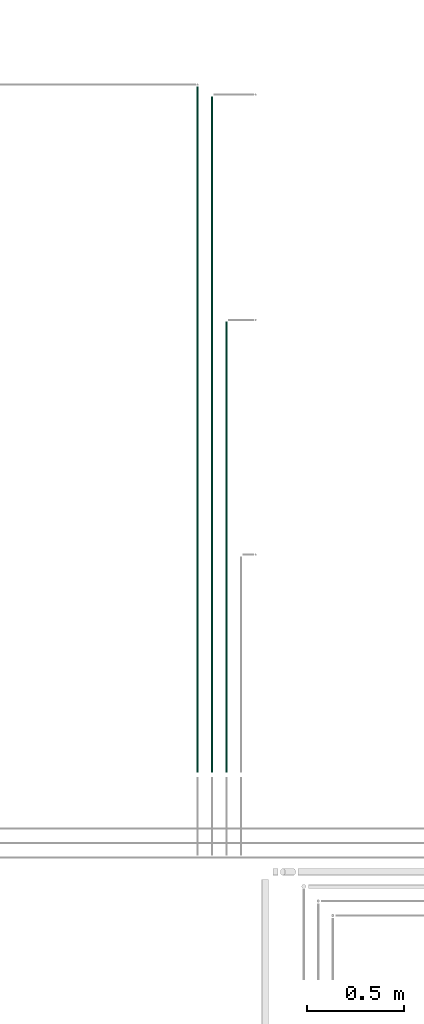
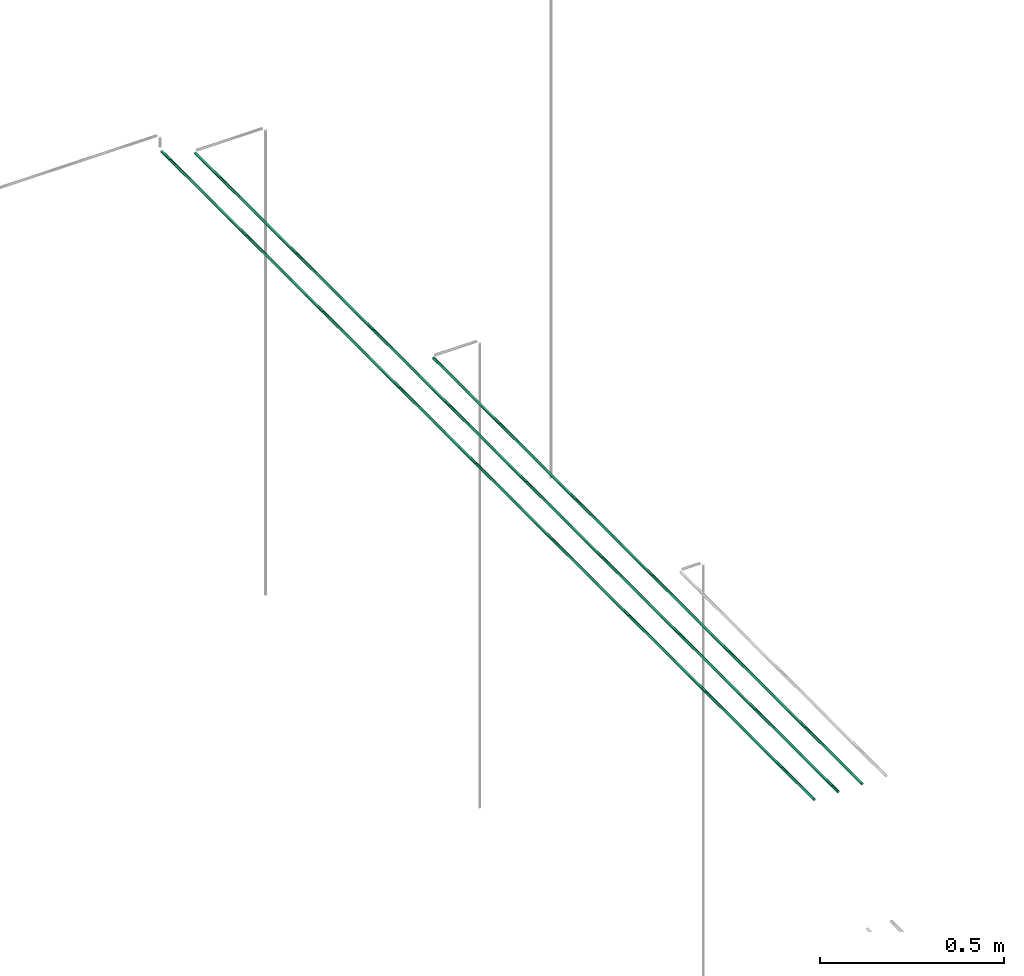
# One storey, part 27 of 331: 3 flow segments.
"""IFC2X3 building model written with IfcOpenShell, lengths in millimetres."""

from ifc_helpers import new_model, entity, si_unit, converted_unit, derived_unit, direction, frame, frame_2d, origin, place, context, subcontext, project, spatial, circle, extrude, type_object, element, save


model = new_model("IFC2X3")

# Units and contexts
model_context = context("Model", 3, precision=0.01, world=origin(), true_north=direction((6.12303176911189e-17, 1.0)))
body_context = subcontext(model_context, "Body", "Model", "MODEL_VIEW")
ifc_project = project(units=[si_unit("LENGTHUNIT", "METRE", prefix="MILLI"), si_unit("AREAUNIT", "SQUARE_METRE"), si_unit("VOLUMEUNIT", "CUBIC_METRE"), converted_unit("PLANEANGLEUNIT", "DEGREE", entity("IfcRatioMeasure", 0.0174532925199433), si_unit("PLANEANGLEUNIT", "RADIAN"), dimensions=[0, 0, 0, 0, 0, 0, 0]), si_unit("MASSUNIT", "GRAM", prefix="KILO"), derived_unit("MASSDENSITYUNIT", [(si_unit("MASSUNIT", "GRAM", prefix="KILO"), 1), (si_unit("LENGTHUNIT", "METRE"), -3)]), derived_unit("MOMENTOFINERTIAUNIT", [(si_unit("LENGTHUNIT", "METRE"), 4)]), si_unit("TIMEUNIT", "SECOND"), si_unit("FREQUENCYUNIT", "HERTZ"), si_unit("THERMODYNAMICTEMPERATUREUNIT", "DEGREE_CELSIUS"), derived_unit("THERMALTRANSMITTANCEUNIT", [(si_unit("MASSUNIT", "GRAM", prefix="KILO"), 1), (si_unit("THERMODYNAMICTEMPERATUREUNIT", "KELVIN"), -1), (si_unit("TIMEUNIT", "SECOND"), -3)]), derived_unit("VOLUMETRICFLOWRATEUNIT", [(si_unit("LENGTHUNIT", "METRE"), 3), (si_unit("TIMEUNIT", "SECOND"), -1)]), derived_unit("MASSFLOWRATEUNIT", [(si_unit("MASSUNIT", "GRAM", prefix="KILO"), 1), (si_unit("TIMEUNIT", "SECOND"), -1)]), derived_unit("ROTATIONALFREQUENCYUNIT", [(si_unit("TIMEUNIT", "SECOND"), -1)]), si_unit("ELECTRICCURRENTUNIT", "AMPERE"), si_unit("ELECTRICVOLTAGEUNIT", "VOLT"), si_unit("POWERUNIT", "WATT"), si_unit("FORCEUNIT", "NEWTON", prefix="KILO"), si_unit("ILLUMINANCEUNIT", "LUX"), si_unit("LUMINOUSFLUXUNIT", "LUMEN"), si_unit("LUMINOUSINTENSITYUNIT", "CANDELA"), derived_unit("USERDEFINED", [(si_unit("MASSUNIT", "GRAM", prefix="KILO"), -1), (si_unit("LENGTHUNIT", "METRE"), -2), (si_unit("TIMEUNIT", "SECOND"), 3), (si_unit("LUMINOUSFLUXUNIT", "LUMEN"), 1)]), derived_unit("LINEARVELOCITYUNIT", [(si_unit("LENGTHUNIT", "METRE"), 1), (si_unit("TIMEUNIT", "SECOND"), -1)]), si_unit("PRESSUREUNIT", "PASCAL"), derived_unit("USERDEFINED", [(si_unit("LENGTHUNIT", "METRE"), -2), (si_unit("MASSUNIT", "GRAM", prefix="KILO"), 1), (si_unit("TIMEUNIT", "SECOND"), -2)]), derived_unit("LINEARFORCEUNIT", [(si_unit("MASSUNIT", "GRAM", prefix="KILO"), 1), (si_unit("LENGTHUNIT", "METRE"), 1), (si_unit("TIMEUNIT", "SECOND"), -2), (si_unit("LENGTHUNIT", "METRE"), -1)]), derived_unit("PLANARFORCEUNIT", [(si_unit("MASSUNIT", "GRAM", prefix="KILO"), 1), (si_unit("LENGTHUNIT", "METRE"), 1), (si_unit("TIMEUNIT", "SECOND"), -2), (si_unit("LENGTHUNIT", "METRE"), -2)])], contexts=[model_context])

# Site, building, storey
site_placement = place(None, frame((0.0, -0.00077364408347762, 0.0)))
site = spatial("IfcSite", under=ifc_project, at=site_placement, CompositionType="ELEMENT")
building_placement = place(site_placement, origin())
building = spatial("IfcBuilding", under=site, at=building_placement, CompositionType="ELEMENT")
storey_placement = place(building_placement, origin())
storey = spatial("IfcBuildingStorey", under=building, at=storey_placement, CompositionType="ELEMENT", Elevation=0.0)

# Flow segments
pipe_segment_type = type_object("IfcPipeSegmentType", PredefinedType="NOTDEFINED")
flow_segment_1_placement = place(storey_placement, frame((34189.88220001, 16340.2503647959, 7244.40472776409)))
element("IfcFlowSegment", 1, at=flow_segment_1_placement, inside=storey, type_object=pipe_segment_type, context=body_context, shape_type="SweptSolid", body=[
    extrude(circle(Radius=4.0, at=frame_2d((5.19776222063229e-11, 3.24860138789518e-12), x_axis=(1.0, 0.0))), frame((5.59527223596697, 0.0, 5.5952722359204), z_axis=(0.0, 1.0, 0.0), x_axis=(-1.0, 0.0, 0.0)), (0.0, 0.0, 1.0), 2328.7350790509),
])
flow_segment_2_placement = place(storey_placement, frame((34114.8822000101, 16340.2503647959, 7244.40472776408)))
element("IfcFlowSegment", 2, at=flow_segment_2_placement, inside=storey, type_object=pipe_segment_type, context=body_context, shape_type="SweptSolid", body=[
    extrude(circle(Radius=4.0, at=frame_2d((-8.66293703438714e-12, 4.33146851719357e-12), x_axis=(1.0, 0.0))), frame((5.59527223592365, 0.0, 5.59527223592257), z_axis=(0.0, 1.0, 0.0), x_axis=(-1.0, 0.0, 0.0)), (0.0, 0.0, 1.0), 3492.73507905091),
])
flow_segment_3_placement = place(storey_placement, frame((34039.8822000101, 16340.2503647959, 7244.40472776406)))
element("IfcFlowSegment", 3, at=flow_segment_3_placement, inside=storey, type_object=pipe_segment_type, context=body_context, shape_type="SweptSolid", body=[
    extrude(circle(Radius=4.0, at=frame_2d((-8.66293703438714e-12, 5.41433564649196e-12), x_axis=(1.0, 0.0))), frame((5.59527223592365, 0.0, 5.59527223592149), z_axis=(0.0, 1.0, 0.0), x_axis=(-1.0, 0.0, 0.0)), (0.0, 0.0, 1.0), 3544.73430540706),
])

save(model, "model.ifc")
